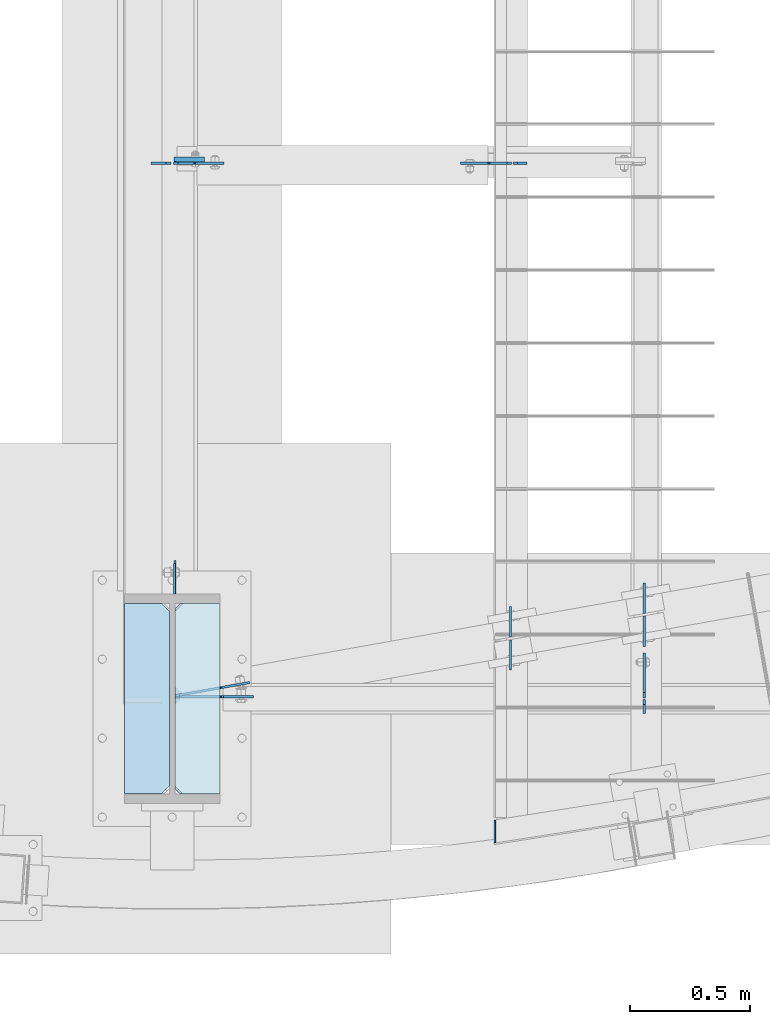
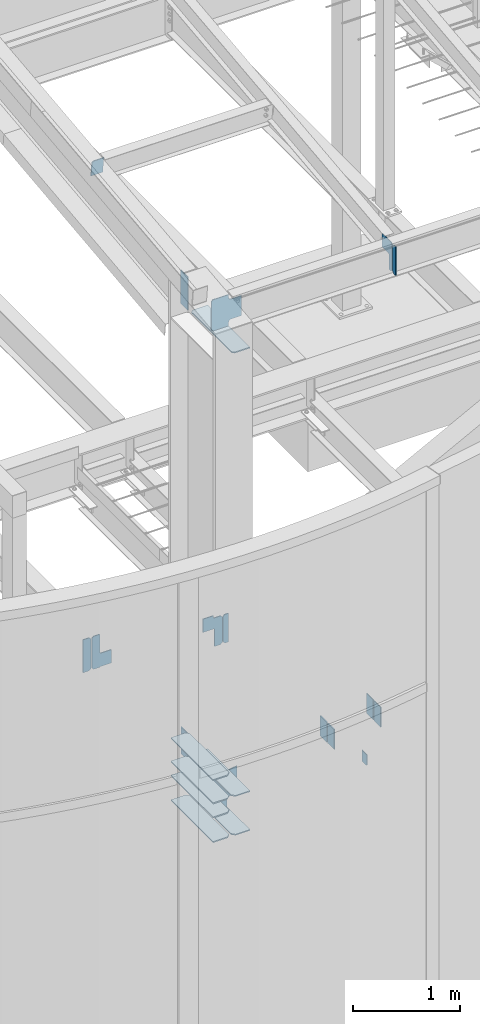
# One storey, part 983 of 1179: 23 plates, 7 elements without a shape of their own.
"""IFC2X3 building model written with IfcOpenShell, lengths in millimetres."""

from ifc_helpers import new_model, si_unit, frame, origin_with_axes, place, context, subcontext, project, spatial, faceted_brep, material, type_object, element, aggregate, save


model = new_model("IFC2X3")

# Units and contexts
model_context = context("Model", 3, precision=1e-05, world=origin_with_axes())
body_context = subcontext(model_context, "Body", "Model", "MODEL_VIEW")
ifc_project = project(units=[si_unit("LENGTHUNIT", "METRE", prefix="MILLI"), si_unit("AREAUNIT", "SQUARE_METRE"), si_unit("VOLUMEUNIT", "CUBIC_METRE"), si_unit("MASSUNIT", "GRAM", prefix="KILO"), si_unit("TIMEUNIT", "SECOND"), si_unit("PLANEANGLEUNIT", "RADIAN"), si_unit("SOLIDANGLEUNIT", "STERADIAN"), si_unit("THERMODYNAMICTEMPERATUREUNIT", "DEGREE_CELSIUS"), si_unit("LUMINOUSINTENSITYUNIT", "LUMEN")], contexts=[model_context])

# Site, building, storey
site_placement = place(None, origin_with_axes())
site = spatial("IfcSite", under=ifc_project, at=site_placement, CompositionType="ELEMENT")
building_placement = place(site_placement, origin_with_axes())
building = spatial("IfcBuilding", under=site, at=building_placement, Name="Undefined", CompositionType="ELEMENT")
storey_placement = place(building_placement, origin_with_axes())
storey = spatial("IfcBuildingStorey", under=building, at=storey_placement, Name="Undefined", CompositionType="ELEMENT", Elevation=0.0)

# Assembly, plates
assembly_1_placement = place(storey_placement, origin_with_axes())
assembly_1 = element("IfcElementAssembly", 1, at=assembly_1_placement, inside=storey, Name="BEAM", AssemblyPlace="NOTDEFINED", PredefinedType="RIGID_FRAME")
ifc_material = material(Name="STEEL/A36")
plate_type_1 = type_object("IfcPlateType", PredefinedType="NOTDEFINED")
plate_1_placement = place(assembly_1_placement, frame((1846.26249990493, 684.214852741619, 3810.0), z_axis=(0.0, -1.0, 0.0), x_axis=(0.0, 0.0, -1.0)))
plate_1 = element("IfcPlate", 2, at=plate_1_placement, type_object=plate_type_1, material=ifc_material, Name="PLATE", context=body_context, shape_type="Brep", body=[
    faceted_brep([(0.0, -4.76249999999709, 0.0), (0.0, -4.76249999999709, 127.0), (0.0, 4.76249999999709, 127.0), (0.0, 4.76249999999709, 0.0), (228.6, -4.76249999999709, 127.0), (228.6, 4.76249999999709, 127.0), (228.6, -4.76249999999709, 0.0), (228.6, 4.76249999999709, 0.0)], [[[0, 1, 2, 3]], [[1, 4, 5, 2]], [[4, 6, 7, 5]], [[6, 0, 3, 7]], [[5, 7, 3, 2]], [[6, 4, 1, 0]]]),
])
plate_2_placement = place(assembly_1_placement, frame((1846.2624998645, 695.5848273489, 3810.0), z_axis=(0.0, 1.0, 0.0), x_axis=(0.0, 0.0, -1.0)))
plate_2 = element("IfcPlate", 3, at=plate_2_placement, type_object=plate_type_1, material=ifc_material, Name="PLATE", context=body_context, shape_type="Brep", body=[
    faceted_brep([(0.0, -4.76249999999709, 0.0), (0.0, -4.76249999999709, 127.0), (0.0, 4.76249999999709, 127.0), (0.0, 4.76249999999709, 0.0), (228.6, -4.76249999999709, 127.0), (228.6, 4.76249999999709, 127.0), (228.6, -4.76249999999709, 0.0), (228.6, 4.76249999999709, 0.0)], [[[0, 1, 2, 3]], [[1, 4, 5, 2]], [[4, 6, 7, 5]], [[6, 0, 3, 7]], [[5, 7, 3, 2]], [[6, 4, 1, 0]]]),
])
plate_3_placement = place(assembly_1_placement, frame((2405.06249986449, 795.041554327276, 3810.0), z_axis=(0.0, 1.0, 0.0), x_axis=(0.0, 0.0, -1.0)))
plate_3 = element("IfcPlate", 4, at=plate_3_placement, type_object=plate_type_1, material=ifc_material, Name="PLATE", context=body_context, shape_type="Brep", body=[
    faceted_brep([(0.0, -4.76249999999709, 0.0), (0.0, -4.76249999999709, 127.0), (0.0, 4.76249999999709, 127.0), (0.0, 4.76249999999709, 0.0), (228.6, -4.76249999999709, 127.0), (228.6, 4.76249999999709, 127.0), (228.6, -4.76249999999709, 0.0), (228.6, 4.76249999999709, 0.0)], [[[0, 1, 2, 3]], [[1, 4, 5, 2]], [[4, 6, 7, 5]], [[6, 0, 3, 7]], [[5, 7, 3, 2]], [[6, 4, 1, 0]]]),
])
plate_4_placement = place(assembly_1_placement, frame((2405.06249990307, 783.671579719879, 3810.0), z_axis=(0.0, -1.0, 0.0), x_axis=(0.0, 0.0, -1.0)))
plate_4 = element("IfcPlate", 5, at=plate_4_placement, type_object=plate_type_1, material=ifc_material, Name="PLATE", context=body_context, shape_type="Brep", body=[
    faceted_brep([(0.0, -4.76249999999709, 0.0), (0.0, -4.76249999999709, 127.0), (0.0, 4.76249999999709, 127.0), (0.0, 4.76249999999709, 0.0), (228.6, -4.76249999999709, 127.0), (228.6, 4.76249999999709, 127.0), (228.6, -4.76249999999709, 0.0), (228.6, 4.76249999999709, 0.0)], [[[0, 1, 2, 3]], [[1, 4, 5, 2]], [[4, 6, 7, 5]], [[6, 0, 3, 7]], [[5, 7, 3, 2]], [[6, 4, 1, 0]]]),
])
aggregate(assembly_1, [plate_1, plate_2, plate_3, plate_4])

# Assembly, plate
assembly_2_placement = place(storey_placement, origin_with_axes())
assembly_2 = element("IfcElementAssembly", 6, at=assembly_2_placement, inside=storey, Name="COLUMN", AssemblyPlace="NOTDEFINED", PredefinedType="RIGID_FRAME")
plate_5_placement = place(assembly_2_placement, frame((442.118750000002, 876.3, 4063.99999886453), z_axis=(0.0, 1.0, 0.0), x_axis=(0.0, 0.0, -1.0)))
plate_5 = element("IfcPlate", 7, at=plate_5_placement, type_object=plate_type_1, material=ifc_material, Name="PLATE", context=body_context, shape_type="Brep", body=[
    faceted_brep([(0.0, -4.76249999999709, 0.0), (0.0, -4.76249999999709, 127.0), (0.0, 4.76249999999709, 127.0), (0.0, 4.76249999999709, 0.0), (304.799999999999, -4.76249999999982, 127.0), (304.799999999999, 4.76249999999982, 127.0), (304.799987792969, -4.76250000000073, 0.0), (304.799987792969, 4.76250000000073, 0.0)], [[[0, 1, 2, 3]], [[2, 1, 4, 5]], [[4, 6, 7, 5]], [[6, 0, 3, 7]], [[5, 7, 3, 2]], [[6, 4, 1, 0]]]),
])

assembly_3_placement = place(storey_placement, origin_with_axes())
assembly_3 = element("IfcElementAssembly", 8, at=assembly_3_placement, inside=storey, Name="BEAM", AssemblyPlace="NOTDEFINED", PredefinedType="RIGID_FRAME")
plate_type_2 = type_object("IfcPlateType", PredefinedType="NOTDEFINED")
plate_6_placement = place(assembly_3_placement, frame((2405.85575008392, 434.97499988271, 8925.52031305008), z_axis=(0.0, 0.0, 1.0), x_axis=(0.0, -1.0, 0.0)))
plate_6 = element("IfcPlate", 9, at=plate_6_placement, type_object=plate_type_2, material=ifc_material, Name="PLATE", context=body_context, shape_type="Brep", body=[
    faceted_brep([(0.0, -4.76250000000073, 22.2250003814697), (0.0, -4.76250000000073, 307.974999618531), (0.0, 4.76250000000073, 307.974999618531), (0.0, 4.76250000000073, 22.2250003814697), (22.2250003814697, -4.76250000000073, 330.200000000001), (22.2250003814697, 4.76250000000073, 330.200000000001), (58.7375, -4.76250000000073, 330.200000000001), (58.7375, 4.76250000000073, 330.200000000001), (58.7375, -4.76250000000073, 0.0), (58.7375, 4.76250000000073, 0.0), (22.2250003814697, -4.76250000000073, 0.0), (22.2250003814697, 4.76250000000073, 0.0)], [[[0, 1, 2, 3]], [[1, 4, 5, 2]], [[4, 6, 7, 5]], [[6, 8, 9, 7]], [[8, 10, 11, 9]], [[10, 0, 3, 11]], [[5, 7, 9, 11, 3, 2]], [[10, 8, 6, 4, 1, 0]]]),
])

assembly_4_placement = place(storey_placement, origin_with_axes())
assembly_4 = element("IfcElementAssembly", 10, at=assembly_4_placement, inside=storey, Name="BEAM", AssemblyPlace="NOTDEFINED", PredefinedType="RIGID_FRAME")
plate_7_placement = place(assembly_4_placement, frame((1857.375, 2675.73174991608, 3508.375), z_axis=(0.0, 0.0, 1.0), x_axis=(1.0, 0.0, 0.0)))
plate_7 = element("IfcPlate", 11, at=plate_7_placement, type_object=plate_type_2, material=ifc_material, Name="PLATE", context=body_context, shape_type="Brep", body=[
    faceted_brep([(0.0, -4.76250000000073, 19.0499992370605), (0.0, -4.76250000000073, 307.974999618531), (0.0, 4.76250000000073, 307.974999618531), (0.0, 4.76250000000073, 19.0499992370605), (19.0499992370605, -4.76249999999982, 327.024993896484), (19.0499992370605, 4.76249999999982, 327.024993896484), (58.7374992370605, -4.76249999999982, 327.024993896484), (58.7374992370605, 4.76249999999982, 327.024993896484), (58.7375, -4.76250000000073, 0.0), (58.7375, 4.76250000000073, 0.0), (19.0499992370605, -4.76250000000073, 0.0), (19.0499992370605, 4.76250000000073, 0.0)], [[[0, 1, 2, 3]], [[1, 4, 5, 2]], [[4, 6, 7, 5]], [[6, 8, 9, 7]], [[8, 10, 11, 9]], [[10, 0, 3, 11]], [[5, 7, 9, 11, 3, 2]], [[10, 8, 6, 4, 1, 0]]]),
])

# Plate
plate_type_3 = type_object("IfcPlateType", PredefinedType="NOTDEFINED")
plate_8_placement = place(assembly_3_placement, frame((2405.85575008392, 441.324999882713, 8947.74531305003), z_axis=(0.0, 0.707106781186542, 0.707106781186553), x_axis=(0.0, 0.707106781186553, -0.707106781186542)))
plate_8 = element("IfcPlate", 12, at=plate_8_placement, type_object=plate_type_3, material=ifc_material, Name="PLATE", context=body_context, shape_type="Brep", body=[
    faceted_brep([(0.0, -4.76249999999709, 0.0), (-202.055762724124, -4.76250000000073, 202.055762724127), (-202.055762724124, 4.76250000000073, 202.055762724127), (0.0, 4.76249999999709, 0.0), (-202.05576272413, -4.76250000000073, 233.486659147874), (-202.05576272413, 4.76250000000073, 233.486659147874), (-85.2817411997539, -4.76250000000073, 350.199296771269), (-85.2817411997539, 4.76250000000073, 350.199296771269), (22.4813322531099, -4.76250000000073, 242.436223318402), (22.4813322531099, 4.76250000000073, 242.436223318402), (-58.3409729713785, -4.76250000000073, 161.613918093915), (-58.3409729713785, 4.76250000000073, 161.613918093915), (-61.093986871856, -4.76250000000073, 157.493741625763), (-61.093986871856, 4.76250000000073, 157.493741625763), (-62.0607167944436, -4.76250000000073, 152.633662107716), (-62.0607167944436, 4.76250000000073, 152.633662107716), (-61.0939868718551, -4.76250000000073, 147.773582589671), (-61.0939868718551, 4.76250000000073, 147.773582589671), (-58.3409729713767, -4.76250000000073, 143.653406121516), (-58.3409729713767, 4.76250000000073, 143.653406121516), (58.3716647869414, -4.76250000000073, 26.9407683631916), (58.3716647869414, 4.76250000000073, 26.9407683631916), (31.4308964237443, -4.76250000000073, -5.45696821063757e-12), (31.4308964237443, 4.76250000000073, -5.45696821063757e-12)], [[[0, 1, 2, 3]], [[1, 4, 5, 2]], [[4, 6, 7, 5]], [[6, 8, 9, 7]], [[8, 10, 11, 9]], [[10, 12, 13, 11]], [[12, 14, 15, 13]], [[14, 16, 17, 15]], [[16, 18, 19, 17]], [[18, 20, 21, 19]], [[20, 22, 23, 21]], [[22, 0, 3, 23]], [[5, 7, 9, 11, 13, 15, 17, 19, 21, 23, 3, 2]], [[22, 20, 18, 16, 14, 12, 10, 8, 6, 4, 1, 0]]]),
])

aggregate(assembly_3, [plate_6, plate_8])

# Assembly, plate
assembly_5_placement = place(storey_placement, origin_with_axes())
assembly_5 = element("IfcElementAssembly", 13, at=assembly_5_placement, inside=storey, Name="BEAM", AssemblyPlace="NOTDEFINED", PredefinedType="RIGID_FRAME")
plate_type_4 = type_object("IfcPlateType", PredefinedType="NOTDEFINED")
plate_9_placement = place(assembly_5_placement, frame((438.943750000001, 2676.77209029896, 9525.39304502119), z_axis=(1.0, 0.0, 0.0), x_axis=(0.0, 0.112284087038014, -0.993676146336441)))
plate_9 = element("IfcPlate", 14, at=plate_9_placement, type_object=plate_type_4, material=ifc_material, Name="PLATE", context=body_context, shape_type="Brep", body=[
    faceted_brep([(0.0, -4.76250000000073, 19.0499992370605), (-3.63797880709171e-12, -4.76249999999709, 127.793749999997), (0.0, 4.76250000000437, 127.793749999997), (0.0, 4.76250000000073, 19.0499992370605), (179.387499999706, -4.762500000008, 127.793750000001), (179.387499999702, 4.76249999999072, 127.793750000001), (179.387499999706, -4.762500000008, 0.0), (179.387499999702, 4.76249999999072, 0.0), (19.0499992370605, -4.76250000000073, 0.0), (19.0499992370605, 4.76250000000073, 0.0)], [[[0, 1, 2, 3]], [[1, 4, 5, 2]], [[4, 6, 7, 5]], [[6, 8, 9, 7]], [[8, 0, 3, 9]], [[5, 7, 9, 3, 2]], [[8, 6, 4, 1, 0]]]),
])
aggregate(assembly_5, [plate_9])

# Plate
plate_type_5 = type_object("IfcPlateType", PredefinedType="NOTDEFINED")
plate_10_placement = place(assembly_2_placement, frame((443.706250000001, 876.299999999952, 9291.80837908497), z_axis=(0.0, 1.0, 0.0), x_axis=(0.0, 0.0, -1.0)))
plate_10 = element("IfcPlate", 15, at=plate_10_placement, type_object=plate_type_5, material=ifc_material, Name="PLATE", context=body_context, shape_type="Brep", body=[
    faceted_brep([(0.0, -4.76249999999709, 0.0), (0.0, -4.76249999999982, 139.699999999997), (0.0, 4.76249999999982, 139.699999999997), (0.0, 4.76249999999709, 0.0), (381.000000000031, -4.76249999999999, 139.700000000086), (381.000000000031, 4.76249999999999, 139.700000000086), (381.0, -4.76249999999999, 8.66293703438714e-11), (381.0, 4.76249999999999, 8.66293703438714e-11)], [[[0, 1, 2, 3]], [[1, 4, 5, 2]], [[4, 6, 7, 5]], [[6, 0, 3, 7]], [[5, 7, 3, 2]], [[6, 4, 1, 0]]]),
])

plate_type_6 = type_object("IfcPlateType", PredefinedType="NOTDEFINED")
plate_11_placement = place(assembly_2_placement, frame((631.825000000001, 41.275, 8922.34531305008), z_axis=(0.0, 1.0, 0.0), x_axis=(-1.0, 0.0, 0.0)))
plate_11 = element("IfcPlate", 16, at=plate_11_placement, type_object=plate_type_6, material=ifc_material, Name="PLATE", context=body_context, shape_type="Brep", body=[
    faceted_brep([(0.0, -6.34999999999854, 0.0), (0.0, -6.35000000000036, 793.75), (0.0, 6.35000000000036, 793.75), (0.0, 6.34999999999854, 0.0), (166.687499618532, -6.35000000000036, 793.75), (166.687499618532, 6.35000000000036, 793.75), (188.912500000002, -6.35000000000036, 771.52499961853), (188.912500000002, 6.35000000000036, 771.52499961853), (188.912500000002, -6.35000000000036, 22.2250003814697), (188.912500000002, 6.35000000000036, 22.2250003814697), (166.687499618532, -6.35000000000036, 0.0), (166.687499618532, 6.35000000000036, 0.0)], [[[0, 1, 2, 3]], [[1, 4, 5, 2]], [[4, 6, 7, 5]], [[6, 8, 9, 7]], [[8, 10, 11, 9]], [[10, 0, 3, 11]], [[5, 7, 9, 11, 3, 2]], [[10, 8, 6, 4, 1, 0]]]),
])

plate_12_placement = place(assembly_2_placement, frame((420.687500000002, 41.275, 3397.25000000002), z_axis=(0.0, 1.0, 0.0), x_axis=(-1.0, 0.0, 0.0)))
plate_12 = element("IfcPlate", 17, at=plate_12_placement, type_object=plate_type_6, material=ifc_material, Name="PLATE", context=body_context, shape_type="Brep", body=[
    faceted_brep([(0.0, -6.34999999999991, 31.75), (0.0, -6.34999999999991, 762.0), (0.0, 6.34999999999991, 762.0), (0.0, 6.34999999999991, 31.75), (31.75, -6.34999999999991, 793.75), (31.75, 6.34999999999991, 793.75), (188.912500000002, -6.35000000000036, 793.75), (188.912500000002, 6.35000000000036, 793.75), (188.912500000002, -6.35000000000036, 0.0), (188.912500000002, 6.35000000000036, 0.0), (31.75, -6.34999999999991, 0.0), (31.75, 6.34999999999991, 0.0)], [[[0, 1, 2, 3]], [[1, 4, 5, 2]], [[4, 6, 7, 5]], [[6, 8, 9, 7]], [[8, 10, 11, 9]], [[10, 0, 3, 11]], [[5, 7, 9, 11, 3, 2]], [[10, 8, 6, 4, 1, 0]]]),
])

plate_13_placement = place(assembly_2_placement, frame((420.687500000002, 41.275, 3841.75000000002), z_axis=(0.0, 1.0, 0.0), x_axis=(-1.0, 0.0, 0.0)))
plate_13 = element("IfcPlate", 18, at=plate_13_placement, type_object=plate_type_6, material=ifc_material, Name="PLATE", context=body_context, shape_type="Brep", body=[
    faceted_brep([(0.0, -6.34999999999991, 31.75), (0.0, -6.34999999999991, 762.0), (0.0, 6.34999999999991, 762.0), (0.0, 6.34999999999991, 31.75), (31.75, -6.34999999999991, 793.75), (31.75, 6.34999999999991, 793.75), (188.912500000002, -6.35000000000036, 793.75), (188.912500000002, 6.35000000000036, 793.75), (188.912500000002, -6.35000000000036, 0.0), (188.912500000002, 6.35000000000036, 0.0), (31.75, -6.34999999999991, 0.0), (31.75, 6.34999999999991, 0.0)], [[[0, 1, 2, 3]], [[1, 4, 5, 2]], [[4, 6, 7, 5]], [[6, 8, 9, 7]], [[8, 10, 11, 9]], [[10, 0, 3, 11]], [[5, 7, 9, 11, 3, 2]], [[10, 8, 6, 4, 1, 0]]]),
])

plate_14_placement = place(assembly_2_placement, frame((631.825000000002, 41.275, 3397.25000000002), z_axis=(0.0, 1.0, 0.0), x_axis=(-1.0, 0.0, 0.0)))
plate_14 = element("IfcPlate", 19, at=plate_14_placement, type_object=plate_type_6, material=ifc_material, Name="PLATE", context=body_context, shape_type="Brep", body=[
    faceted_brep([(0.0, -6.34999999999854, 0.0), (0.0, -6.35000000000036, 793.75), (0.0, 6.35000000000036, 793.75), (0.0, 6.34999999999854, 0.0), (157.162506103516, -6.34999999999991, 793.75), (157.162506103516, 6.34999999999991, 793.75), (188.912506103516, -6.34999999999991, 762.0), (188.912506103516, 6.34999999999991, 762.0), (188.912506103516, -6.34999999999991, 31.75), (188.912506103516, 6.34999999999991, 31.75), (157.162499999999, -6.34999999999854, 0.0), (157.162499999999, 6.34999999999854, 0.0)], [[[0, 1, 2, 3]], [[1, 4, 5, 2]], [[4, 6, 7, 5]], [[6, 8, 9, 7]], [[8, 10, 11, 9]], [[10, 0, 3, 11]], [[5, 7, 9, 11, 3, 2]], [[10, 8, 6, 4, 1, 0]]]),
])

plate_15_placement = place(assembly_2_placement, frame((631.825000000002, 41.275, 3841.75000000002), z_axis=(0.0, 1.0, 0.0), x_axis=(-1.0, 0.0, 0.0)))
plate_15 = element("IfcPlate", 20, at=plate_15_placement, type_object=plate_type_6, material=ifc_material, Name="PLATE", context=body_context, shape_type="Brep", body=[
    faceted_brep([(0.0, -6.34999999999854, 0.0), (0.0, -6.35000000000036, 793.75), (0.0, 6.35000000000036, 793.75), (0.0, 6.34999999999854, 0.0), (157.162506103516, -6.34999999999991, 793.75), (157.162506103516, 6.34999999999991, 793.75), (188.912506103516, -6.34999999999991, 762.0), (188.912506103516, 6.34999999999991, 762.0), (188.912506103516, -6.34999999999991, 31.75), (188.912506103516, 6.34999999999991, 31.75), (157.162499999999, -6.34999999999854, 0.0), (157.162499999999, 6.34999999999854, 0.0)], [[[0, 1, 2, 3]], [[1, 4, 5, 2]], [[4, 6, 7, 5]], [[6, 8, 9, 7]], [[8, 10, 11, 9]], [[10, 0, 3, 11]], [[5, 7, 9, 11, 3, 2]], [[10, 8, 6, 4, 1, 0]]]),
])

plate_16_placement = place(assembly_2_placement, frame((420.687500000002, 41.275, 4108.45), z_axis=(0.0, 1.0, 0.0), x_axis=(-1.0, 0.0, 0.0)))
plate_16 = element("IfcPlate", 21, at=plate_16_placement, type_object=plate_type_6, material=ifc_material, Name="PLATE", context=body_context, shape_type="Brep", body=[
    faceted_brep([(0.0, -6.34999999999991, 31.75), (0.0, -6.34999999999991, 762.0), (0.0, 6.34999999999991, 762.0), (0.0, 6.34999999999991, 31.75), (31.75, -6.34999999999991, 793.75), (31.75, 6.34999999999991, 793.75), (188.912500000002, -6.35000000000036, 793.75), (188.912500000002, 6.35000000000036, 793.75), (188.912500000002, -6.35000000000036, 0.0), (188.912500000002, 6.35000000000036, 0.0), (31.75, -6.34999999999991, 0.0), (31.75, 6.34999999999991, 0.0)], [[[0, 1, 2, 3]], [[1, 4, 5, 2]], [[4, 6, 7, 5]], [[6, 8, 9, 7]], [[8, 10, 11, 9]], [[10, 0, 3, 11]], [[5, 7, 9, 11, 3, 2]], [[10, 8, 6, 4, 1, 0]]]),
])

plate_17_placement = place(assembly_2_placement, frame((420.687500000002, 41.275, 3679.825), z_axis=(0.0, 1.0, 0.0), x_axis=(-1.0, 0.0, 0.0)))
plate_17 = element("IfcPlate", 22, at=plate_17_placement, type_object=plate_type_6, material=ifc_material, Name="PLATE", context=body_context, shape_type="Brep", body=[
    faceted_brep([(0.0, -6.34999999999991, 31.75), (0.0, -6.34999999999991, 762.0), (0.0, 6.34999999999991, 762.0), (0.0, 6.34999999999991, 31.75), (31.75, -6.34999999999991, 793.75), (31.75, 6.34999999999991, 793.75), (188.912500000002, -6.35000000000036, 793.75), (188.912500000002, 6.35000000000036, 793.75), (188.912500000002, -6.35000000000036, 0.0), (188.912500000002, 6.35000000000036, 0.0), (31.75, -6.34999999999991, 0.0), (31.75, 6.34999999999991, 0.0)], [[[0, 1, 2, 3]], [[1, 4, 5, 2]], [[4, 6, 7, 5]], [[6, 8, 9, 7]], [[8, 10, 11, 9]], [[10, 0, 3, 11]], [[5, 7, 9, 11, 3, 2]], [[10, 8, 6, 4, 1, 0]]]),
])

plate_type_7 = type_object("IfcPlateType", PredefinedType="NOTDEFINED")
plate_18_placement = place(assembly_2_placement, frame((443.746939998421, 449.951545771693, 3422.65), z_axis=(0.696166228097253, 0.123905538017309, 0.707106781543979), x_axis=(0.696166228831761, 0.123905537970056, -0.707106780829116)))
plate_18 = element("IfcPlate", 23, at=plate_18_placement, type_object=plate_type_7, material=ifc_material, Name="PLATE", context=body_context, shape_type="Brep", body=[
    faceted_brep([(0.0, -4.76249999999709, 0.0), (-278.387939753241, -4.76250000000374, 278.387939753233), (-278.387939753243, 4.76249999999658, 278.387939753234), (0.0, 4.76249999999709, 0.0), (-278.387939753246, -4.76250000000357, 305.328708116445), (-278.387939753248, 4.76249999999669, 305.328708116446), (-156.036597608128, -4.76250000000107, 427.680050261562), (-156.03659760813, 4.76249999999925, 427.680050261564), (-147.056341352184, -4.76250000000095, 418.699794005619), (-147.056341352185, 4.76249999999931, 418.69979400562), (-142.93616488403, -4.7625000000009, 415.946780105141), (-142.936164884031, 4.76249999999942, 415.946780105142), (-138.076085365984, -4.76250000000078, 414.980050182552), (-138.076085365985, 4.76249999999948, 414.980050182553), (-133.216005847938, -4.76250000000073, 415.94678010514), (-133.216005847939, 4.76249999999959, 415.946780105141), (-129.095829379784, -4.76250000000067, 418.699794005617), (-129.095829379785, 4.76249999999965, 418.699794005619), (-49.4722717589452, -4.76249999999908, 498.323351626456), (-49.4722717589475, 4.76250000000124, 498.323351626457), (166.053875146791, -4.76249999999635, 282.797204720727), (166.053875146789, 4.76250000000397, 282.797204720728), (86.4303175259524, -4.762499999998, 203.173647099888), (86.4303175259508, 4.76250000000232, 203.173647099889), (83.6773036254745, -4.76249999999811, 199.053470631735), (83.6773036254731, 4.76250000000232, 199.053470631736), (82.7105737028869, -4.76249999999811, 194.193391113688), (82.7105737028855, 4.76250000000221, 194.19339111369), (83.6773036254754, -4.76249999999806, 189.333311595642), (83.6773036254738, 4.76250000000221, 189.333311595644), (86.4303175259543, -4.762499999998, 185.213135127488), (86.4303175259524, 4.76250000000226, 185.21313512749), (149.292110508332, -4.7624999999972, 122.351342145113), (149.292110508331, 4.762500000003, 122.351342145114), (26.9407683631525, -4.76249999999709, -6.18456397205591e-11), (26.9407683631525, 4.76249999999709, -6.18456397205591e-11)], [[[0, 1, 2, 3]], [[1, 4, 5, 2]], [[4, 6, 7, 5]], [[6, 8, 9, 7]], [[8, 10, 11, 9]], [[10, 12, 13, 11]], [[12, 14, 15, 13]], [[14, 16, 17, 15]], [[16, 18, 19, 17]], [[18, 20, 21, 19]], [[20, 22, 23, 21]], [[22, 24, 25, 23]], [[24, 26, 27, 25]], [[26, 28, 29, 27]], [[28, 30, 31, 29]], [[30, 32, 33, 31]], [[32, 34, 35, 33]], [[34, 0, 3, 35]], [[5, 7, 9, 11, 13, 15, 17, 19, 21, 23, 25, 27, 29, 31, 33, 35, 3, 2]], [[34, 32, 30, 28, 26, 24, 22, 20, 18, 16, 14, 12, 10, 8, 6, 4, 1, 0]]]),
])

# Assembly, plate
assembly_6_placement = place(storey_placement, origin_with_axes())
assembly_6 = element("IfcElementAssembly", 24, at=assembly_6_placement, inside=storey, Name="BEAM", AssemblyPlace="NOTDEFINED", PredefinedType="RIGID_FRAME")
plate_type_8 = type_object("IfcPlateType", PredefinedType="NOTDEFINED")
plate_19_placement = place(assembly_6_placement, frame((426.243750000002, 2675.73174991608, 3705.225), z_axis=(0.0, 0.0, 1.0), x_axis=(-1.0, 0.0, 0.0)))
plate_19 = element("IfcPlate", 25, at=plate_19_placement, type_object=plate_type_8, material=ifc_material, Name="PLATE", context=body_context, shape_type="Brep", body=[
    faceted_brep([(0.0, -4.76250000000073, 19.0499992370605), (0.0, -4.76249999999709, 358.775000762939), (0.0, 4.76249999999709, 358.775000762939), (0.0, 4.76250000000073, 19.0499992370605), (19.0499992370605, -4.76249999999709, 377.825), (19.0499992370605, 4.76249999999709, 377.825), (83.34375, -4.76249999999982, 377.825012207031), (83.34375, 4.76249999999982, 377.825012207031), (83.34375, -4.76249999999982, 0.0), (83.34375, 4.76249999999982, 0.0), (19.0499992370605, -4.76250000000073, 0.0), (19.0499992370605, 4.76250000000073, 0.0)], [[[0, 1, 2, 3]], [[1, 4, 5, 2]], [[4, 6, 7, 5]], [[6, 8, 9, 7]], [[8, 10, 11, 9]], [[10, 0, 3, 11]], [[5, 7, 9, 11, 3, 2]], [[10, 8, 6, 4, 1, 0]]]),
])

# Plate
plate_type_9 = type_object("IfcPlateType", PredefinedType="NOTDEFINED")
plate_20_placement = place(assembly_2_placement, frame((442.912500000002, 446.08749988271, 8947.74531305009), z_axis=(0.707106781186573, 0.0, 0.707106781186522), x_axis=(0.707106781186522, 0.0, -0.707106781186573)))
plate_20 = element("IfcPlate", 26, at=plate_20_placement, type_object=plate_type_9, material=ifc_material, Name="PLATE", context=body_context, shape_type="Brep", body=[
    faceted_brep([(0.0, -4.76249999999709, 0.0), (-226.470816375611, -4.76249999999999, 226.470816375618), (-226.470816375611, 4.76249999999999, 226.470816375618), (0.0, 4.76249999999709, 0.0), (-226.470816375654, -4.76249999999999, 253.411584738797), (-226.470816375654, 4.76249999999999, 253.411584738797), (-106.359890756637, -4.76249999999999, 373.52251035781), (-106.359890756637, 4.76249999999999, 373.52251035781), (-81.9448368353978, -4.76249999999999, 349.107456436569), (-81.9448368353978, 4.76249999999999, 349.107456436569), (-73.7044838990896, -4.76249999999999, 343.601428635614), (-73.7044838990896, 4.76249999999999, 343.601428635614), (-63.9843248629977, -4.76249999999999, 341.667968790437), (-63.9843248629977, 4.76249999999999, 341.667968790437), (-54.2641658269058, -4.76249999999999, 343.601428635612), (-54.2641658269058, 4.76249999999999, 343.601428635612), (-46.0238128905976, -4.76249999999999, 349.107456436567), (-46.0238128905976, 4.76249999999999, 349.107456436567), (34.798492468527, -4.76249999999999, 429.929761795689), (34.798492468527, 4.76249999999999, 429.929761795689), (196.443102647823, -4.76249999999999, 268.285151616388), (196.443102647823, 4.76249999999999, 268.285151616388), (115.620797288699, -4.76249999999999, 187.462846257265), (115.620797288699, 4.76249999999999, 187.462846257265), (110.114769487744, -4.76249999999999, 179.222493320958), (110.114769487744, 4.76249999999999, 179.222493320958), (108.181309642569, -4.76249999999999, 169.502334284865), (108.181309642569, 4.76249999999999, 169.502334284865), (110.114769487745, -4.76249999999999, 159.782175248773), (110.114769487745, 4.76249999999999, 159.782175248773), (115.620797288702, -4.76249999999999, 151.541822312464), (115.620797288702, 4.76249999999999, 151.541822312464), (147.051693982197, -4.76249999999999, 120.110925618969), (147.051693982197, 4.76249999999999, 120.110925618969), (26.9407683631525, -4.76249999999709, -6.18456397205591e-11), (26.9407683631525, 4.76249999999709, -6.18456397205591e-11)], [[[0, 1, 2, 3]], [[1, 4, 5, 2]], [[4, 6, 7, 5]], [[6, 8, 9, 7]], [[8, 10, 11, 9]], [[10, 12, 13, 11]], [[12, 14, 15, 13]], [[14, 16, 17, 15]], [[16, 18, 19, 17]], [[18, 20, 21, 19]], [[20, 22, 23, 21]], [[22, 24, 25, 23]], [[24, 26, 27, 25]], [[26, 28, 29, 27]], [[28, 30, 31, 29]], [[30, 32, 33, 31]], [[32, 34, 35, 33]], [[34, 0, 3, 35]], [[5, 7, 9, 11, 13, 15, 17, 19, 21, 23, 25, 27, 29, 31, 33, 35, 3, 2]], [[34, 32, 30, 28, 26, 24, 22, 20, 18, 16, 14, 12, 10, 8, 6, 4, 1, 0]]]),
])

aggregate(assembly_2, [plate_10, plate_11, plate_20, plate_12, plate_13, plate_14, plate_15, plate_18, plate_16, plate_17, plate_5])

plate_type_10 = type_object("IfcPlateType", PredefinedType="NOTDEFINED")
plate_21_placement = place(assembly_4_placement, frame((1851.025, 2675.73174991608, 3527.425), z_axis=(-0.707106781186532, 0.0, 0.707106781186563), x_axis=(-0.707106781186564, 0.0, -0.707106781186531)))
plate_21 = element("IfcPlate", 27, at=plate_21_placement, type_object=plate_type_10, material=ifc_material, Name="PLATE", context=body_context, shape_type="Brep", body=[
    faceted_brep([(-51.6364724785985, -4.76249999999982, 208.7909554491), (-60.61672407888, -4.76249999999982, 199.810693676288), (-60.61672407888, 4.76249999999982, 199.810693676288), (-51.6364724785985, 4.76249999999982, 208.7909554491), (-63.3697379787222, -4.76249999999982, 195.690517209667), (-63.3697379787222, 4.76249999999982, 195.690517209667), (-64.3364679019428, -4.76249999999982, 190.830437693406), (-64.3364679019428, 4.76249999999982, 190.830437693406), (-63.369737981257, -4.76249999999982, 185.970358176639), (-63.369737981257, 4.76249999999982, 185.970358176639), (-60.6167240835634, -4.76249999999982, 181.850181708579), (-60.6167240835634, 4.76249999999982, 181.850181708579), (74.0871114326292, -4.76249999999982, 47.1463460517127), (74.0871117377783, 4.76249999999982, 47.1463457465636), (-87.557495117253, -4.76249999999982, 388.396087646501), (20.205577850295, -4.76249999999982, 280.632995605468), (20.205577850295, 4.76249999999982, 280.632995605468), (-87.557495117253, 4.76249999999982, 388.396087646501), (-168.379806518607, -4.76249999999982, 307.573760986357), (-168.379806518607, 4.76249999999982, 307.573760986357), (-157.154487621452, -4.76249999999982, 296.348450566303), (-157.154487621452, 4.76249999999982, 296.348450566303), (-154.401471706463, -4.76249999999982, 292.228274030069), (-154.401471706463, 4.76249999999982, 292.228274030069), (-153.434740407541, -4.76249999999982, 287.368193586949), (-153.434740407541, 4.76249999999982, 287.368193586949), (-154.401469871351, -4.76249999999982, 282.508112778803), (-154.401469871351, 4.76249999999982, 282.508112778803), (-157.154484230605, -4.76249999999982, 278.387935203063), (-157.154484230605, 4.76249999999982, 278.387935203063), (-204.300827026408, -4.76249999999982, 231.24159240726), (-204.300827026408, 4.76249999999982, 231.24159240726), (-204.300827026403, -4.76249999999982, 204.300827026401), (-204.300827026403, 4.76249999999982, 204.300827026401), (0.0, -4.76249999999709, 0.0), (0.0, 4.76249999999709, 0.0), (26.9407683631525, -4.76249999999709, -6.18456397205591e-11), (26.9407683631525, 4.76249999999709, -6.18456397205591e-11)], [[[0, 1, 2, 3]], [[4, 5, 2, 1]], [[6, 7, 5, 4]], [[8, 9, 7, 6]], [[10, 11, 9, 8]], [[12, 13, 11, 10]], [[14, 15, 16, 17]], [[18, 14, 17, 19]], [[20, 18, 19, 21]], [[22, 20, 21, 23]], [[24, 22, 23, 25]], [[26, 24, 25, 27]], [[28, 26, 27, 29]], [[30, 28, 29, 31]], [[32, 30, 31, 33]], [[34, 32, 33, 35]], [[36, 34, 35, 37]], [[8, 6, 4, 1, 0, 15, 14, 18, 20, 22, 24, 26, 28, 30, 32, 34, 36, 12, 10]], [[15, 0, 3, 16]], [[37, 35, 33, 31, 29, 27, 25, 23, 21, 19, 17, 16, 3, 2, 5, 7, 9, 11, 13]], [[36, 37, 13, 12]]]),
])

aggregate(assembly_4, [plate_7, plate_21])

plate_22_placement = place(assembly_6_placement, frame((437.356250000002, 2675.73174991608, 3724.275), z_axis=(0.707106781186573, 0.0, 0.707106781186522), x_axis=(0.707106781186522, 0.0, -0.707106781186573)))
plate_22 = element("IfcPlate", 28, at=plate_22_placement, type_object=plate_type_10, material=ifc_material, Name="PLATE", context=body_context, shape_type="Brep", body=[
    faceted_brep([(0.0, -4.76249999999709, 0.0), (-240.221851238686, -4.76249999999709, 240.221851238675), (-240.221851238686, 4.76249999999709, 240.221851238675), (0.0, 4.76249999999709, 0.0), (-240.221851238757, -4.76249999999709, 267.162619601822), (-240.221851238757, 4.76249999999709, 267.162619601822), (-193.636779785198, -4.76249999999982, 313.747711181685), (-193.636779785198, 4.76249999999982, 313.747711181685), (-47.7076113710432, -4.76249999999982, 167.818542767529), (-47.7076113710432, 4.76249999999982, 167.818542767529), (-43.5874350897948, -4.76249999999982, 165.06552894447), (-43.5874350897948, 4.76249999999982, 165.06552894447), (-38.7273557894528, -4.76249999999982, 164.098798944462), (-38.7273557894528, 4.76249999999982, 164.098798944462), (-33.8672764275134, -4.76249999999982, 165.065528634794), (-33.8672764275134, 4.76249999999982, 165.065528634794), (-29.747099970848, -4.76249999999982, 167.818542195324), (-29.747099970848, 4.76249999999982, 167.818542195324), (51.0752067565768, -4.76249999999982, 248.640838623065), (51.0752067565768, 4.76249999999982, 248.640838623065), (158.838287353518, -4.76249999999982, 140.87776184082), (158.838287353518, 4.76249999999982, 140.87776184082), (73.5258493905012, -4.76249999999982, 55.5653347496905), (73.5258493905012, 4.76249999999982, 55.5653347496905), (72.1493422702883, -4.76249999999982, 53.5052465098693), (72.1493422702883, 4.76249999999982, 53.5052465098693), (71.6659771928666, -4.76249999999982, 51.0752066727932), (71.6659771928666, 4.76249999999982, 51.0752066727932), (72.1493421154514, -4.76249999999982, 48.6451668049176), (72.1493421154514, 4.76249999999982, 48.6451668049176), (73.5258483886746, -4.76249999999982, 46.5850791931134), (73.5258483886746, 4.76249999999982, 46.5850791931134), (26.9407683631525, -4.76249999999709, -6.18456397205591e-11), (26.9407683631525, 4.76249999999709, -6.18456397205591e-11)], [[[0, 1, 2, 3]], [[1, 4, 5, 2]], [[4, 6, 7, 5]], [[6, 8, 9, 7]], [[8, 10, 11, 9]], [[10, 12, 13, 11]], [[12, 14, 15, 13]], [[14, 16, 17, 15]], [[16, 18, 19, 17]], [[18, 20, 21, 19]], [[20, 22, 23, 21]], [[22, 24, 25, 23]], [[24, 26, 27, 25]], [[26, 28, 29, 27]], [[28, 30, 31, 29]], [[30, 32, 33, 31]], [[32, 0, 3, 33]], [[5, 7, 9, 11, 13, 15, 17, 19, 21, 23, 25, 27, 29, 31, 33, 3, 2]], [[32, 30, 28, 26, 24, 22, 20, 18, 16, 14, 12, 10, 8, 6, 4, 1, 0]]]),
])

aggregate(assembly_6, [plate_19, plate_22])

# Assembly, plate
assembly_7_placement = place(storey_placement, origin_with_axes())
assembly_7 = element("IfcElementAssembly", 29, at=assembly_7_placement, inside=storey, Name="BENT_PLATE", AssemblyPlace="NOTDEFINED", PredefinedType="RIGID_FRAME")
plate_type_11 = type_object("IfcPlateType", PredefinedType="NOTDEFINED")
plate_23_placement = place(assembly_7_placement, frame((1781.17500371963, -164.641543743596, 3981.4497997099), z_axis=(0.0, 0.0, -1.0), x_axis=(0.0, 1.0, 0.0)))
plate_23 = element("IfcPlate", 30, at=plate_23_placement, type_object=plate_type_11, material=ifc_material, Name="PLATE", context=body_context, shape_type="Brep", body=[
    faceted_brep([(0.0, -3.17500000000109, 0.0), (0.0, -3.17499999999995, 114.300000190735), (0.0, 3.17499999999995, 114.300000190735), (0.0, 3.17500000000109, 7.27595761418343e-12), (12.6999998092651, -3.17499999999995, 127.0), (12.6999998092651, 3.17499999999995, 127.0), (95.25, -3.17499999999995, 127.0), (95.25, 3.17499999999995, 127.0), (95.25, -3.17499999999995, 0.0), (95.25, 3.17499999999995, 0.0)], [[[0, 1, 2, 3]], [[1, 4, 5, 2]], [[4, 6, 7, 5]], [[6, 8, 9, 7]], [[8, 0, 3, 9]], [[5, 7, 9, 3, 2]], [[8, 6, 4, 1, 0]]]),
])
aggregate(assembly_7, [plate_23])

save(model, "model.ifc")
